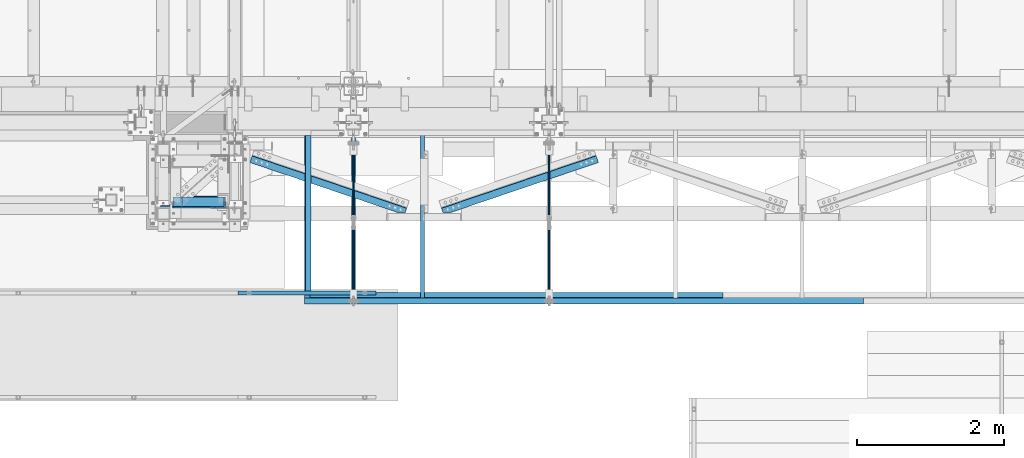
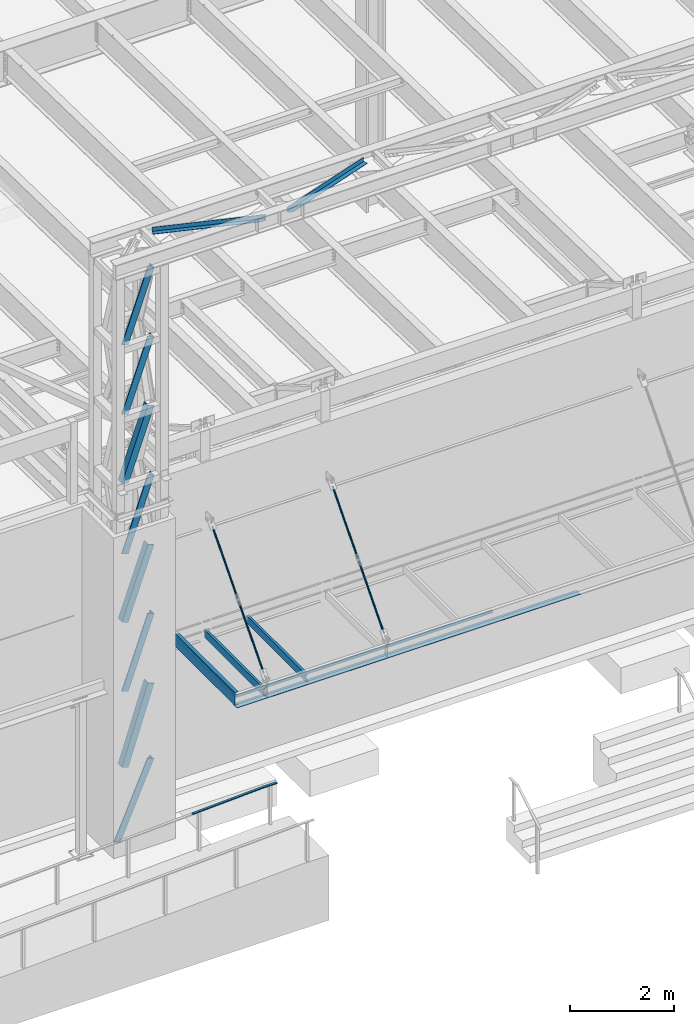
# One storey, part 1052 of 1763: 12 members, 9 beams, 10 elements without a shape of their own.
"""IFC2X3 building model written with IfcOpenShell, lengths in millimetres."""

import ifcopenshell
import ifcopenshell.guid

model = None  # the IFC model being written
_history = None  # IfcOwnerHistory: only IFC2X3 demands one
_inside = {}  # id of a spatial element -> (the spatial element, [elements in it])
_under = {}  # id of a project, library or spatial element -> (it, [spatial elements below it])
_declared = {}  # id of a project -> (the project, [libraries it declares])
_typed = {}  # id of a type object -> (the type object, [elements of that type])
_made_of = {}  # id of a material, layer set ... -> (it, [elements and type objects made of it])


def new_model(schema):
    """Start an empty IFC model of exactly this schema.

    Asked for "IFC4X3", IfcOpenShell would pick the latest addendum, in which some entities
    have other attributes; the version numbers below select the first issue.
    IFC2X3 requires an IfcOwnerHistory on every rooted entity: one is made here for all.
    """
    global model, _history
    if schema == "IFC4X3":
        model = ifcopenshell.file(schema_version=(4, 3, 0, 0))
    else:
        model = ifcopenshell.file(schema=schema)
    _inside.clear()
    _under.clear()
    _declared.clear()
    _typed.clear()
    _made_of.clear()
    _history = None
    if model.schema == "IFC2X3":
        org = make("IfcOrganization", Name="unknown")
        user = make(
            "IfcPersonAndOrganization",
            ThePerson=make("IfcPerson", FamilyName="unknown"),
            TheOrganization=org,
        )
        app = make(
            "IfcApplication",
            ApplicationDeveloper=org,
            Version="unknown",
            ApplicationFullName="unknown",
            ApplicationIdentifier="unknown",
        )
        _history = make(
            "IfcOwnerHistory",
            OwningUser=user,
            OwningApplication=app,
            ChangeAction="ADDED",
            CreationDate=0,
        )
    return model


def make(cls, **values):
    """One entity of the class cls with the attributes given. An attribute that is None is left unset."""
    return model.create_entity(
        cls, **{name: value for name, value in values.items() if value is not None}
    )


def rooted(cls, **values):
    """An entity with a GlobalId (a new one), such as an element, a storey or a relation."""
    return make(cls, GlobalId=ifcopenshell.guid.new(), OwnerHistory=_history, **values)


def si_unit(unit_type, name, prefix=None):
    """IfcSIUnit, for example si_unit("LENGTHUNIT", "METRE", prefix="MILLI")."""
    return make("IfcSIUnit", UnitType=unit_type, Prefix=prefix, Name=name)


def assignment(units):
    """IfcUnitAssignment: the units of a project."""
    return None if units is None else make("IfcUnitAssignment", Units=units)


def point(xyz):
    """IfcCartesianPoint."""
    return None if xyz is None else make("IfcCartesianPoint", Coordinates=xyz)


def direction(xyz):
    """IfcDirection."""
    return None if xyz is None else make("IfcDirection", DirectionRatios=xyz)


def frame(location, z_axis=None, x_axis=None):
    """IfcAxis2Placement3D, a coordinate frame: its origin and axes. An axis left out is left unset."""
    return make(
        "IfcAxis2Placement3D",
        Location=point(location),
        Axis=direction(z_axis),
        RefDirection=direction(x_axis),
    )


def origin_with_axes():
    """The frame at (0, 0, 0) with the z axis (0, 0, 1) and the x axis (1, 0, 0) written out."""
    return frame((0.0, 0.0, 0.0), z_axis=(0.0, 0.0, 1.0), x_axis=(1.0, 0.0, 0.0))


def place(relative_to, where):
    """IfcLocalPlacement: puts the frame where relative to a parent placement (None: the world)."""
    return make(
        "IfcLocalPlacement", PlacementRelTo=relative_to, RelativePlacement=where
    )


def context(
    kind, dimensions, precision=None, world=None, true_north=None, identifier=None
):
    """IfcGeometricRepresentationContext, for example the 3D "Model" context."""
    return make(
        "IfcGeometricRepresentationContext",
        ContextIdentifier=identifier,
        ContextType=kind,
        CoordinateSpaceDimension=dimensions,
        Precision=precision,
        WorldCoordinateSystem=world,
        TrueNorth=true_north,
    )


def subcontext(parent, identifier, kind, view, scale=None):
    """IfcGeometricRepresentationSubContext, for example "Body" below "Model"."""
    return make(
        "IfcGeometricRepresentationSubContext",
        ContextIdentifier=identifier,
        ContextType=kind,
        ParentContext=parent,
        TargetScale=scale,
        TargetView=view,
    )


def project(units=None, contexts=None):
    """IfcProject with its units and contexts."""
    return rooted(
        "IfcProject",
        Name="project",
        RepresentationContexts=contexts,
        UnitsInContext=assignment(units),
    )


def spatial(cls, under=None, at=None, **own):
    """A site, building, storey or space (cls), placed at a placement, below another one or the project."""
    s = rooted(cls, ObjectPlacement=at, **own)
    if under is not None:
        _under.setdefault(under.id(), (under, []))[1].append(s)
    return s


def faces_of(points, faces, orient=None, outer=None):
    """IfcFace entities. A face is a list of loops; a loop is a list of indices into points, from 0.

    orient and outer hold one flag for each loop. By default every Orientation is true, the
    first loop of a face is its IfcFaceOuterBound and the others are IfcFaceBound.
    """
    made = []
    for i, loops in enumerate(faces):
        bounds = []
        for j, loop in enumerate(loops):
            is_outer = j == 0 if outer is None else outer[i][j]
            bounds.append(
                make(
                    "IfcFaceOuterBound" if is_outer else "IfcFaceBound",
                    Bound=make("IfcPolyLoop", Polygon=[points[k] for k in loop]),
                    Orientation=True if orient is None else orient[i][j],
                )
            )
        made.append(make("IfcFace", Bounds=bounds))
    return made


def faceted_brep(points, faces, orient=None, outer=None, voids=None):
    """IfcFacetedBrep: a solid bounded by flat faces; with voids (closed shells), ...WithVoids."""
    shared = [point(p) for p in points]
    hull = make("IfcClosedShell", CfsFaces=faces_of(shared, faces, orient, outer))
    if voids is None:
        return make("IfcFacetedBrep", Outer=hull)
    return make(
        "IfcFacetedBrepWithVoids",
        Outer=hull,
        Voids=[
            make(cls, CfsFaces=faces_of(shared, fs, o, b)) for cls, fs, o, b in voids
        ],
    )


def shape(context_of_items, identifier, shape_type, items):
    """IfcShapeRepresentation: the items that make up one representation, for example the "Body"."""
    return make(
        "IfcShapeRepresentation",
        ContextOfItems=context_of_items,
        RepresentationIdentifier=identifier,
        RepresentationType=shape_type,
        Items=items,
    )


def material(Name=None, Category=None):
    """IfcMaterial."""
    return make("IfcMaterial", Name=Name, Category=Category)


def made_of(thing, what):
    """Note that an element or type object is made of a material, layer set ...; save() writes the relation."""
    if what is not None:
        _made_of.setdefault(what.id(), (what, []))[1].append(thing)
    return thing


def type_object(cls, material=None, **own):
    """A type object (cls), such as IfcWallType, which elements share."""
    return made_of(rooted(cls, **own), material)


def element(
    cls,
    number,
    at=None,
    inside=None,
    cuts=None,
    type_object=None,
    material=None,
    context=None,
    identifier="Body",
    shape_type=None,
    held_by="IfcProductDefinitionShape",
    body=None,
    shapes=None,
    **own,
):
    """One element of the class cls, such as IfcWall. Its Tag is "e" and its number.

    at: its placement. inside: the storey or other place that contains it. cuts: it is an
    opening in that element (IfcRelVoidsElement). A single representation is given by context,
    identifier, shape_type and body (its items); several are given by shapes. held_by: the class
    of the entity that holds the representations. save() writes the other relations.
    """
    e = rooted(cls, Tag="e%d" % number, ObjectPlacement=at, **own)
    if body is not None:
        shapes = [shape(context, identifier, shape_type, body)]
    if shapes is not None:
        e.Representation = make(held_by, Representations=shapes)
    if inside is not None:
        _inside.setdefault(inside.id(), (inside, []))[1].append(e)
    if cuts is not None:
        rooted(
            "IfcRelVoidsElement", RelatingBuildingElement=cuts, RelatedOpeningElement=e
        )
    if type_object is not None:
        _typed.setdefault(type_object.id(), (type_object, []))[1].append(e)
    return made_of(e, material)


def aggregate(whole, parts):
    """IfcRelAggregates: a whole, such as a stair, and the parts it consists of."""
    return rooted("IfcRelAggregates", RelatingObject=whole, RelatedObjects=parts)


def save(model, path):
    """Write the relations noted so far, then the file.

    IfcRelAggregates (storeys below a building ...), IfcRelContainedInSpatialStructure (elements
    in a storey), IfcRelDefinesByType, IfcRelAssociatesMaterial and IfcRelDeclares: one each for
    every whole, place, type object, material and project.
    """
    for whole, parts in _under.values():
        aggregate(whole, parts)
    for where, things in _inside.values():
        rooted(
            "IfcRelContainedInSpatialStructure",
            RelatedElements=things,
            RelatingStructure=where,
        )
    for kind, things in _typed.values():
        rooted("IfcRelDefinesByType", RelatedObjects=things, RelatingType=kind)
    for what, things in _made_of.values():
        rooted("IfcRelAssociatesMaterial", RelatedObjects=things, RelatingMaterial=what)
    for by, libraries in _declared.values():
        rooted("IfcRelDeclares", RelatingContext=by, RelatedDefinitions=libraries)
    model.write(path)


model = new_model("IFC2X3")

# Units and contexts
model_context = context("Model", 3, precision=1e-05, world=origin_with_axes())
body_context = subcontext(model_context, "Body", "Model", "MODEL_VIEW")
ifc_project = project(units=[si_unit("LENGTHUNIT", "METRE", prefix="MILLI"), si_unit("AREAUNIT", "SQUARE_METRE"), si_unit("VOLUMEUNIT", "CUBIC_METRE"), si_unit("MASSUNIT", "GRAM", prefix="KILO"), si_unit("TIMEUNIT", "SECOND"), si_unit("PLANEANGLEUNIT", "RADIAN"), si_unit("SOLIDANGLEUNIT", "STERADIAN"), si_unit("THERMODYNAMICTEMPERATUREUNIT", "DEGREE_CELSIUS"), si_unit("LUMINOUSINTENSITYUNIT", "LUMEN")], contexts=[model_context])

# Site, building, storey
site_placement = place(None, origin_with_axes())
site = spatial("IfcSite", under=ifc_project, at=site_placement, CompositionType="ELEMENT")
building_placement = place(site_placement, origin_with_axes())
building = spatial("IfcBuilding", under=site, at=building_placement, Name="Undefined", CompositionType="ELEMENT")
storey_placement = place(building_placement, origin_with_axes())
storey = spatial("IfcBuildingStorey", under=building, at=storey_placement, Name="Undefined", CompositionType="ELEMENT", Elevation=0.0)

# Assembly, members
assembly_1_placement = place(storey_placement, origin_with_axes())
assembly_1 = element("IfcElementAssembly", 1, at=assembly_1_placement, inside=storey, Name="FRAME", AssemblyPlace="NOTDEFINED", PredefinedType="RIGID_FRAME")
ifc_material_1 = material(Name="STEEL/A36")
member_type_1 = type_object("IfcMemberType", Name="L6X6X7/8", PredefinedType="NOTDEFINED")
member_1_placement = place(assembly_1_placement, frame((-63987.0213595113, -15300.3290302764, 16748.720313), z_axis=(-5.63699999961987e-06, 0.999999999984112, 0.0), x_axis=(0.335283282133074, 2.03400000119903e-06, 0.942117360373927)))
member_1 = element("IfcMember", 2, at=member_1_placement, type_object=member_type_1, material=ifc_material_1, Name="V. BRACE", ObjectType="L6X6X7/8", context=body_context, shape_type="Brep", body=[
    faceted_brep([(9.09494701772928e-13, 76.2000000000007, -76.2000000000844), (0.0, 76.2000000000007, 76.2000000000771), (1724.84329343789, 76.1999999996478, 76.2000000010958), (1724.84329343754, 76.2000000000044, -76.1999999989348), (0.0, 53.9750000000004, 76.2000000000771), (1724.84329343786, 53.9749999996711, 76.2000000010812), (1.81898940354586e-12, 53.9750000000004, -53.9750000000604), (1724.84329343756, 53.9749999999767, -53.9749999989453), (1.81898940354586e-12, -76.2000000000007, -53.9750000000604), (1724.84329343738, -76.1999999998734, -53.9749999990436), (9.09494701772928e-13, -76.2000000000007, -76.2000000000844), (1724.84329343733, -76.1999999998225, -76.1999999990512)], [[[0, 1, 2, 3]], [[1, 4, 5, 2]], [[4, 6, 7, 5]], [[6, 8, 9, 7]], [[8, 10, 11, 9]], [[10, 0, 3, 11]], [[5, 7, 9, 11, 3, 2]], [[10, 8, 6, 4, 1, 0]]]),
])
member_2_placement = place(assembly_1_placement, frame((-63986.7900957031, -15300.3290302764, 15123.7156239956), z_axis=(0.0, 1.0, 0.0), x_axis=(0.334874224906127, 9.99999833869425e-10, 0.942262836735866)))
member_2 = element("IfcMember", 3, at=member_2_placement, type_object=member_type_1, material=ifc_material_1, Name="V. BRACE", ObjectType="L6X6X7/8", context=body_context, shape_type="Brep", body=[
    faceted_brep([(9.09494701772928e-13, 76.2000000000007, -76.2000000000844), (0.0, 76.2000000000007, 76.2000000000771), (1724.57686399414, 76.1999999983163, 76.1999999992258), (1724.57686399422, 76.1999999981927, -76.2000000007738), (0.0, 53.9750000000004, 76.2000000000771), (1724.57686399418, 53.974999998245, 76.1999999992295), (1.81898940354586e-12, 53.9750000000004, -53.9750000000604), (1724.57686399425, 53.9749999981432, -53.9750000007716), (1.81898940354586e-12, -76.2000000000007, -53.9750000000604), (1724.57686399449, -76.2000000022381, -53.9750000007571), (9.09494701772928e-13, -76.2000000000007, -76.2000000000844), (1724.5768639945, -76.2000000022599, -76.2000000007574)], [[[0, 1, 2, 3]], [[1, 4, 5, 2]], [[4, 6, 7, 5]], [[6, 8, 9, 7]], [[8, 10, 11, 9]], [[10, 0, 3, 11]], [[5, 7, 9, 11, 3, 2]], [[10, 8, 6, 4, 1, 0]]]),
])
member_3_placement = place(assembly_1_placement, frame((-63987.4603919911, -15300.3290302764, 13498.7109359956), z_axis=(0.941969969892365, 3.99999953515362e-09, -0.335697148961644), x_axis=(0.335697148961641, 9.99999941453763e-10, 0.941969969892367)))
member_3 = element("IfcMember", 4, at=member_3_placement, type_object=member_type_1, material=ifc_material_1, Name="V. BRACE", ObjectType="L6X6X7/8", context=body_context, shape_type="Brep", body=[
    faceted_brep([(9.09494701772928e-13, 76.2000000000007, -76.2000000000844), (0.0, 76.2000000000007, 76.2000000000771), (1725.11328041713, 76.1999999975596, 76.1999999991767), (1725.11328041723, 76.1999999976688, -76.2000000008229), (0.0, 53.9750000000004, 76.2000000000771), (1725.11328041714, 53.9749999975757, 76.1999999991931), (1.81898940354586e-12, 53.9750000000004, -53.9750000000604), (1725.11328041723, 53.9749999976702, -53.975000000808), (1.81898940354586e-12, -76.2000000000007, -53.9750000000604), (1725.11328041727, -76.2000000022526, -53.9750000007098), (9.09494701772928e-13, -76.2000000000007, -76.2000000000844), (1725.11328041728, -76.2000000022454, -76.2000000007101)], [[[0, 1, 2, 3]], [[1, 4, 5, 2]], [[4, 6, 7, 5]], [[6, 8, 9, 7]], [[8, 10, 11, 9]], [[10, 0, 3, 11]], [[5, 7, 9, 11, 3, 2]], [[10, 8, 6, 4, 1, 0]]]),
])
member_4_placement = place(assembly_1_placement, frame((-63986.5973864284, -15300.3290302764, 11849.0999999956), z_axis=(0.0, 1.0, 0.0), x_axis=(0.330549340153199, 9.99999554506466e-10, 0.943788712437421)))
member_4 = element("IfcMember", 5, at=member_4_placement, type_object=member_type_1, material=ifc_material_1, Name="V. BRACE", ObjectType="L6X6X7/8", context=body_context, shape_type="Brep", body=[
    faceted_brep([(9.09494701772928e-13, 76.2000000000007, -76.2000000000844), (0.0, 76.2000000000007, 76.2000000000771), (1747.86042051722, 76.1999999938562, 76.199999999164), (1747.86042051722, 76.1999999937107, -76.2000000008356), (0.0, 53.9750000000004, 76.2000000000771), (1747.86042051722, 53.9749999938722, 76.1999999991804), (1.81898940354586e-12, 53.9750000000004, -53.9750000000604), (1747.86042051722, 53.9749999937558, -53.9750000008189), (1.81898940354586e-12, -76.2000000000007, -53.9750000000604), (1747.86042051721, -76.2000000061671, -53.9750000007189), (9.09494701772928e-13, -76.2000000000007, -76.2000000000844), (1747.86042051721, -76.2000000061889, -76.2000000007192)], [[[0, 1, 2, 3]], [[1, 4, 5, 2]], [[4, 6, 7, 5]], [[6, 8, 9, 7]], [[8, 10, 11, 9]], [[10, 0, 3, 11]], [[5, 7, 9, 11, 3, 2]], [[10, 8, 6, 4, 1, 0]]]),
])
member_5_placement = place(assembly_1_placement, frame((-63986.1285602919, -15300.3290302764, 10248.701776542), z_axis=(0.942338290337835, 3.99999953515361e-09, -0.334661839119978), x_axis=(0.33466183911998, 9.99999794265608e-10, 0.942338290337834)))
member_5 = element("IfcMember", 6, at=member_5_placement, type_object=member_type_1, material=ifc_material_1, Name="V. BRACE", ObjectType="L6X6X7/8", context=body_context, shape_type="Brep", body=[
    faceted_brep([(9.09494701772928e-13, 76.2000000000007, -76.2000000000844), (0.0, 76.2000000000007, 76.2000000000771), (1724.4605169534, 76.1999999968903, 76.199999999204), (1724.46051695335, 76.1999999966574, -76.2000000007956), (0.0, 53.9750000000004, 76.2000000000771), (1724.46051695341, 53.9749999968262, 76.1999999992131), (1.81898940354586e-12, 53.9750000000004, -53.9750000000604), (1724.46051695337, 53.9749999966371, -53.975000000788), (1.81898940354586e-12, -76.2000000000007, -53.9750000000604), (1724.46051695341, -76.2000000037297, -53.9750000007334), (9.09494701772928e-13, -76.2000000000007, -76.2000000000844), (1724.4605169534, -76.2000000037588, -76.2000000007338)], [[[0, 1, 2, 3]], [[1, 4, 5, 2]], [[4, 6, 7, 5]], [[6, 8, 9, 7]], [[8, 10, 11, 9]], [[10, 0, 3, 11]], [[5, 7, 9, 11, 3, 2]], [[10, 8, 6, 4, 1, 0]]]),
])
member_6_placement = place(assembly_1_placement, frame((-63986.7095248402, -15300.3290302764, 8623.3), z_axis=(0.0, 1.0, 0.0), x_axis=(0.334512951060313, 1.00000043783993e-09, 0.942391153169914)))
member_6 = element("IfcMember", 7, at=member_6_placement, type_object=member_type_1, material=ifc_material_1, Name="V. BRACE", ObjectType="L6X6X7/8", context=body_context, shape_type="Brep", body=[
    faceted_brep([(9.09494701772928e-13, 76.2000000000007, -76.2000000000844), (0.0, 76.2000000000007, 76.2000000000771), (1724.76317823229, 76.1999999951586, 76.1999999991876), (1724.76317823233, 76.199999994933, -76.200000000812), (0.0, 53.9750000000004, 76.2000000000771), (1724.7631782323, 53.97499999516, 76.1999999992004), (1.81898940354586e-12, 53.9750000000004, -53.9750000000604), (1724.76317823234, 53.9749999949636, -53.9750000007989), (1.81898940354586e-12, -76.2000000000007, -53.9750000000604), (1724.76317823241, -76.2000000050757, -53.975000000717), (9.09494701772928e-13, -76.2000000000007, -76.2000000000844), (1724.76317823241, -76.2000000050975, -76.2000000007174)], [[[0, 1, 2, 3]], [[1, 4, 5, 2]], [[4, 6, 7, 5]], [[6, 8, 9, 7]], [[8, 10, 11, 9]], [[10, 0, 3, 11]], [[5, 7, 9, 11, 3, 2]], [[10, 8, 6, 4, 1, 0]]]),
])
member_7_placement = place(assembly_1_placement, frame((-63985.9949216758, -15300.3290302764, 6845.30021654201), z_axis=(0.951343767819845, 3.99999953515362e-09, -0.30813152294165), x_axis=(0.308131522941648, 1.00000004810686e-09, 0.951343767819846)))
member_7 = element("IfcMember", 8, at=member_7_placement, type_object=member_type_1, material=ifc_material_1, Name="V. BRACE", ObjectType="L6X6X7/8", context=body_context, shape_type="Brep", body=[
    faceted_brep([(9.09494701772928e-13, 76.2000000000007, -76.2000000000844), (0.0, 76.2000000000007, 76.2000000000771), (1868.93512461962, 76.199999997596, 76.1999999991676), (1868.93512461956, 76.1999999976761, -76.2000000008338), (0.0, 53.9750000000004, 76.2000000000771), (1868.9351246196, 53.9749999976411, 76.1999999991676), (1.81898940354586e-12, 53.9750000000004, -53.9750000000604), (1868.93512461955, 53.9749999977066, -53.9750000008316), (1.81898940354586e-12, -76.2000000000007, -53.9750000000604), (1868.93512461943, -76.2000000020707, -53.975000000828), (9.09494701772928e-13, -76.2000000000007, -76.2000000000844), (1868.93512461942, -76.2000000020489, -76.2000000008265)], [[[0, 1, 2, 3]], [[1, 4, 5, 2]], [[4, 6, 7, 5]], [[6, 8, 9, 7]], [[8, 10, 11, 9]], [[10, 0, 3, 11]], [[5, 7, 9, 11, 3, 2]], [[10, 8, 6, 4, 1, 0]]]),
])
member_8_placement = place(assembly_1_placement, frame((-64185.2277918511, -15287.629029286, 5067.3), z_axis=(0.0, 1.0, 0.0), x_axis=(0.400955294202786, 1.00000025355767e-09, 0.916097621463323)))
member_8 = element("IfcMember", 9, at=member_8_placement, type_object=member_type_1, material=ifc_material_1, Name="V. BRACE", ObjectType="L6X6X7/8", context=body_context, shape_type="Brep", body=[
    faceted_brep([(74.9404777348027, 76.199999999888, -76.2000000000044), (74.9404778871212, 76.1999999996915, 76.1999999999953), (1940.84119258349, 76.2000000036787, 76.1999999991021), (1940.84119258334, 76.2000000038752, -76.2000000008975), (74.9404778871649, 53.9749999997148, 76.200000000008), (1940.84119258348, 53.9750000036947, 76.1999999991149), (74.9404777570599, 53.9749999998676, -53.9749999999931), (1940.84119258335, 53.9750000038621, -53.9750000008862), (74.9404777573181, -76.2000000000189, -53.9749999999312), (1940.84119258335, -76.199999996039, -53.9750000008244), (74.9404777351083, -76.1999999999971, -76.1999999999316), (1940.84119258333, -76.1999999960099, -76.2000000008247)], [[[0, 1, 2, 3]], [[1, 4, 5, 2]], [[4, 6, 7, 5]], [[6, 8, 9, 7]], [[8, 10, 11, 9]], [[10, 0, 3, 11]], [[5, 7, 9, 11, 3, 2]], [[10, 8, 6, 4, 1, 0]]]),
])
aggregate(assembly_1, [member_1, member_2, member_3, member_4, member_5, member_6, member_7, member_8])

# Assembly, beam
assembly_2_placement = place(storey_placement, origin_with_axes())
assembly_2 = element("IfcElementAssembly", 10, at=assembly_2_placement, inside=storey, Name="BEAM", AssemblyPlace="NOTDEFINED", PredefinedType="RIGID_FRAME")
beam_type_1 = type_object("IfcBeamType", Name="C12X20.7", PredefinedType="NOTDEFINED")
beam_1_placement = place(assembly_2_placement, frame((-62222.878570321, -16605.2525869816, 8585.2), z_axis=(0.0, 0.0, 1.0), x_axis=(0.0, 1.0, 0.0)))
beam_1 = element("IfcBeam", 11, at=beam_1_placement, type_object=beam_type_1, material=ifc_material_1, Name="BEAM", ObjectType="C12X20.7", context=body_context, shape_type="Brep", body=[
    faceted_brep([(0.0, 38.1000000000004, -152.4), (0.0, 38.1000000000004, 152.4), (2295.52500000448, 38.0999999999985, 152.4), (2295.52500000448, 38.0999999999985, -152.4), (0.0, -38.1000000000004, 152.4), (2295.52500000448, -38.0999999999985, 152.4), (0.0, -38.1000000000004, 146.04746), (2295.52500000448, -38.0999999999985, 146.04746), (0.0, 30.1625000000004, 134.6749275), (2295.52500000448, 30.1624999999985, 134.6749275), (0.0, 30.1625000000004, -134.6749275), (2295.52500000448, 30.1624999999985, -134.6749275), (0.0, -38.1000000000004, -146.04746), (2295.52500000448, -38.0999999999985, -146.04746), (0.0, -38.1000000000004, -152.4), (2295.52500000448, -38.0999999999985, -152.4)], [[[0, 1, 2, 3]], [[1, 4, 5, 2]], [[4, 6, 7, 5]], [[6, 8, 9, 7]], [[8, 10, 11, 9]], [[10, 12, 13, 11]], [[12, 14, 15, 13]], [[14, 0, 3, 15]], [[5, 7, 9, 11, 13, 15, 3, 2]], [[14, 12, 10, 8, 6, 4, 1, 0]]]),
])

assembly_3_placement = place(storey_placement, origin_with_axes())
assembly_3 = element("IfcElementAssembly", 12, at=assembly_3_placement, inside=storey, Name="ANGLE", AssemblyPlace="NOTDEFINED", PredefinedType="RIGID_FRAME")
beam_type_2 = type_object("IfcBeamType", Name="L4X4X1/4", PredefinedType="NOTDEFINED")
beam_2_placement = place(assembly_3_placement, frame((-60647.6330235447, -15500.8450363274, 18672.175), z_axis=(-0.320645554004404, -0.947199255013014, 0.0), x_axis=(-0.947199255013015, 0.320645554004401, 0.0)))
beam_2 = element("IfcBeam", 13, at=beam_2_placement, type_object=beam_type_2, material=ifc_material_1, Name="ANGLE", ObjectType="L4X4X1/4", context=body_context, shape_type="Brep", body=[
    faceted_brep([(248.935656765898, 44.4500000000007, 15.0335884778251), (248.935656765898, 50.7999999999993, 15.0335884778251), (248.93475632761, 50.7999999999993, -50.7999999996973), (248.93475632761, -50.7999999999993, -50.7999999996973), (248.934843627998, -50.7999999999993, -44.4500000001863), (248.934843627998, 44.4500000000007, -44.4500000001863), (354.576694317358, 44.4500000000007, 50.7951525150202), (354.576694317358, 50.7999999999993, 50.7999999998283), (2474.101738043, 44.4500000000007, 50.7994905337837), (2474.101738043, 50.7999999999993, 50.7999999985695), (2474.10174137646, 50.7999999999993, -50.7999999971726), (2474.10174137646, -50.7999999999993, -50.7999999971726), (2474.1017380429, -50.7999999999993, -44.4500000015032), (2474.1017380429, 44.4500000000007, -44.4500000015032)], [[[0, 1, 2, 3, 4, 5]], [[6, 7, 1, 0]], [[7, 6, 8, 9]], [[2, 1, 7, 9, 10]], [[3, 2, 10, 11]], [[4, 3, 11, 12]], [[5, 4, 12, 13]], [[6, 0, 5, 13, 8]], [[12, 11, 10, 9, 8, 13]]]),
])
aggregate(assembly_3, [beam_2])

assembly_4_placement = place(storey_placement, origin_with_axes())
assembly_4 = element("IfcElementAssembly", 14, at=assembly_4_placement, inside=storey, Name="ANGLE", AssemblyPlace="NOTDEFINED", PredefinedType="RIGID_FRAME")
beam_3_placement = place(assembly_4_placement, frame((-58035.897064475, -14627.719968568, 18672.175), z_axis=(0.320645554004404, -0.947199255013014, 0.0), x_axis=(-0.947199255013014, -0.320645554004406, 0.0)))
beam_3 = element("IfcBeam", 15, at=beam_3_placement, type_object=beam_type_2, material=ifc_material_1, Name="ANGLE", ObjectType="L4X4X1/4", context=body_context, shape_type="Brep", body=[
    faceted_brep([(2474.08768654509, 44.4500000000007, -44.4499999985737), (2474.08768654509, -50.7999999999993, -44.4499999985737), (2474.08778122983, -50.7999999999993, -50.7999999984352), (2474.08778122983, 50.7999999999993, -50.7999999984352), (2474.08687340719, 50.7999999999993, 15.0335884763126), (2474.08687340719, 44.4500000000007, 15.0335884763126), (2368.44583585572, 50.7999999999993, 50.8000000014445), (2368.44583585572, 44.4500000000007, 50.8000000014445), (248.920792117679, 44.4500000000007, 50.8000000001839), (248.92079211778, 44.4500000000007, -44.4499999998907), (248.92079211778, -50.7999999999993, -44.4499999998907), (248.920795180988, -50.7999999999993, -50.7999999998303), (248.920795180988, 50.7999999999993, -50.7999999998303), (248.920792117679, 50.7999999999993, 50.8000000001839)], [[[0, 1, 2, 3, 4, 5]], [[5, 4, 6, 7]], [[0, 5, 7, 8, 9]], [[1, 0, 9, 10]], [[2, 1, 10, 11]], [[3, 2, 11, 12]], [[6, 4, 3, 12, 13]], [[7, 6, 13, 8]], [[12, 11, 10, 9, 8, 13]]]),
])
aggregate(assembly_4, [beam_3])

# Beam
beam_type_3 = type_object("IfcBeamType", Name="L3X3X1/4", PredefinedType="NOTDEFINED")
beam_4_placement = place(assembly_2_placement, frame((-62214.9410885321, -14389.1026138803, 8648.7), z_axis=(1.0, 0.0, 0.0), x_axis=(0.0, -1.0, 0.0)))
beam_4 = element("IfcBeam", 16, at=beam_4_placement, type_object=beam_type_3, material=ifc_material_1, Name="ANGLE", ObjectType="L3X3X1/4", context=body_context, shape_type="Brep", body=[
    faceted_brep([(0.0, 38.0999999999985, -38.1000000000004), (0.0, 38.0999999999985, 38.1000000000004), (2127.24997269495, 38.1000000000004, 38.1000000007625), (2127.24997269498, 38.1000000000004, -38.0999999992346), (0.0, 31.75, 38.1000000000058), (2127.24997269495, 31.75, 38.1000000007625), (0.0, 31.75, -31.75), (2127.24997269498, 31.75, -31.749999999236), (0.0, -38.1000000000004, -31.75), (2127.24997269498, -38.1000000000004, -31.749999999236), (0.0, -38.0999999999985, -38.1000000000004), (2127.24997269498, -38.1000000000004, -38.0999999992346)], [[[0, 1, 2, 3]], [[1, 4, 5, 2]], [[4, 6, 7, 5]], [[6, 8, 9, 7]], [[8, 10, 11, 9]], [[10, 0, 3, 11]], [[5, 7, 9, 11, 3, 2]], [[10, 8, 6, 4, 1, 0]]]),
])

aggregate(assembly_2, [beam_4, beam_1])

# Assembly, beam
assembly_5_placement = place(storey_placement, origin_with_axes())
assembly_5 = element("IfcElementAssembly", 17, at=assembly_5_placement, inside=storey, Name="BEAM", AssemblyPlace="NOTDEFINED", PredefinedType="RIGID_FRAME")
beam_5_placement = place(assembly_5_placement, frame((-62240.3410736523, -16567.1525870962, 8648.7), z_axis=(0.0, 1.0, 0.0), x_axis=(1.0, 0.0, 0.0)))
beam_5 = element("IfcBeam", 18, at=beam_5_placement, type_object=beam_type_3, material=ifc_material_1, Name="ANGLE", ObjectType="L3X3X1/4", context=body_context, shape_type="Brep", body=[
    faceted_brep([(0.0, 38.0999999999985, -38.1000000000004), (0.0, 38.0999999999985, 38.1000000000004), (5686.02812397742, 38.1000000000004, 38.0999999921842), (5686.02812397732, 38.1000000000004, -38.1000000078166), (0.0, 31.75, 38.1000000000058), (5686.02812397742, 31.75, 38.0999999921842), (0.0, 31.75, -31.75), (5686.02812397732, 31.75, -31.7500000078144), (0.0, -38.1000000000004, -31.75), (5686.02812397732, -38.1000000000004, -31.7500000078144), (0.0, -38.0999999999985, -38.1000000000004), (5686.02812397732, -38.1000000000004, -38.1000000078166)], [[[0, 1, 2, 3]], [[1, 4, 5, 2]], [[4, 6, 7, 5]], [[6, 8, 9, 7]], [[8, 10, 11, 9]], [[10, 0, 3, 11]], [[5, 7, 9, 11, 3, 2]], [[10, 8, 6, 4, 1, 0]]]),
])

assembly_6_placement = place(storey_placement, origin_with_axes())
assembly_6 = element("IfcElementAssembly", 19, at=assembly_6_placement, inside=storey, Name="HANDRAIL", AssemblyPlace="NOTDEFINED", PredefinedType="RIGID_FRAME")
beam_type_4 = type_object("IfcBeamType", PredefinedType="NOTDEFINED")
beam_6_placement = place(assembly_6_placement, frame((-63170.3544175437, -16535.40011631, 6173.15296081485), z_axis=(0.0, 1.0, 0.0), x_axis=(0.998862153652615, 0.0, 0.0476906489834141)))
beam_6 = element("IfcBeam", 20, at=beam_6_placement, type_object=beam_type_4, material=ifc_material_1, Name="HANDRAIL", context=body_context, shape_type="Brep", body=[
    faceted_brep([(2.91038304567337e-11, -9.52499999999418, -25.4000000000015), (2.91038304567337e-11, -9.52499999999418, 25.4000000000015), (-5.82076609134674e-11, 9.52499999999418, 25.4000000000015), (-5.82076609134674e-11, 9.52499999999418, -25.4000000000015), (1577.64893967877, 9.5250031540254, 25.4000000000015), (1577.64893967877, 9.5250031540254, -25.4000000000015), (1578.10337826535, -9.52499684506802, -25.4000000000015), (1578.10337826535, -9.52499684506802, 25.4000000000015), (1881.72603368139, 24.0408078176079, 25.4000000000015), (1881.72603368139, 24.0408078176079, -25.4000000000015), (1882.63439390225, 5.01247678966138, 25.4000000000015), (1882.63439390225, 5.01247678966138, -25.4000000000015)], [[[0, 1, 2, 3]], [[3, 2, 4, 5]], [[1, 0, 6, 7]], [[5, 4, 8, 9]], [[4, 2, 1, 7, 10, 8]], [[7, 6, 11, 10]], [[6, 0, 3, 5, 9, 11]], [[10, 11, 9, 8]]]),
])
aggregate(assembly_6, [beam_6])

# Beam
beam_type_5 = type_object("IfcBeamType", PredefinedType="NOTDEFINED")
beam_7_placement = place(assembly_5_placement, frame((-62260.9785706929, -16605.2525869363, 8426.45), z_axis=(0.0, 1.0, 0.0), x_axis=(1.0, 0.0, 0.0)))
beam_7 = element("IfcBeam", 21, at=beam_7_placement, type_object=beam_type_5, material=ifc_material_1, Name="PLATE", context=body_context, shape_type="Brep", body=[
    faceted_brep([(4.36557456851006e-11, 6.35000000000036, -76.2000000000044), (-4.72937244921923e-11, 6.35000000000036, 76.1999999999898), (7619.80156200011, 6.35000000000036, 76.1999999891996), (7619.80156199988, 6.35000000000036, -76.2000000107982), (-4.72937244921923e-11, -6.35000000000036, 76.1999999999898), (7619.80156200011, -6.35000000000036, 76.1999999891996), (4.36557456851006e-11, -6.35000000000036, -76.2000000000044), (7619.80156199988, -6.35000000000036, -76.2000000107982)], [[[0, 1, 2, 3]], [[1, 4, 5, 2]], [[4, 6, 7, 5]], [[6, 0, 3, 7]], [[5, 7, 3, 2]], [[6, 4, 1, 0]]]),
])

aggregate(assembly_5, [beam_5, beam_7])

# Assembly, beam
assembly_7_placement = place(storey_placement, origin_with_axes())
assembly_7 = element("IfcElementAssembly", 22, at=assembly_7_placement, inside=storey, Name="BEAM", AssemblyPlace="NOTDEFINED", PredefinedType="RIGID_FRAME")
beam_type_6 = type_object("IfcBeamType", Name="C7X9.8", PredefinedType="NOTDEFINED")
beam_8_placement = place(assembly_7_placement, frame((-61594.4270098568, -16605.2525869816, 8521.7), z_axis=(0.0, 0.0, 1.0), x_axis=(0.0, 1.0, 0.0)))
beam_8 = element("IfcBeam", 23, at=beam_8_placement, type_object=beam_type_6, material=ifc_material_1, Name="BEAM", ObjectType="C7X9.8", context=body_context, shape_type="Brep", body=[
    faceted_brep([(0.0, 26.9875000000029, -88.8999999999996), (0.0, 26.9875000000029, 88.8999999999996), (2295.52499752098, 26.9875000000029, 88.8999999999996), (2295.52499752098, 26.9875000000029, -88.8999999999996), (0.0, -26.9875000000029, 88.8999999999996), (2295.52499752098, -26.9875000000029, 88.8999999999996), (0.0, -26.9875000000029, 83.8711175000008), (2295.52499752098, -26.9875000000029, 83.8711175000008), (0.0, 22.2249999999985, 75.6723149999998), (2295.52499752098, 22.2249999999985, 75.6723149999998), (0.0, 22.2249999999985, -75.6723149999998), (2295.52499752098, 22.2249999999985, -75.6723149999998), (0.0, -26.9875000000029, -83.8711175000008), (2295.52499752098, -26.9875000000029, -83.8711175000008), (0.0, -26.9875000000029, -88.8999999999996), (2295.52499752098, -26.9875000000029, -88.8999999999996)], [[[0, 1, 2, 3]], [[1, 4, 5, 2]], [[4, 6, 7, 5]], [[6, 8, 9, 7]], [[8, 10, 11, 9]], [[10, 12, 13, 11]], [[12, 14, 15, 13]], [[14, 0, 3, 15]], [[5, 7, 9, 11, 13, 15, 3, 2]], [[14, 12, 10, 8, 6, 4, 1, 0]]]),
])
aggregate(assembly_7, [beam_8])

assembly_8_placement = place(storey_placement, origin_with_axes())
assembly_8 = element("IfcElementAssembly", 24, at=assembly_8_placement, inside=storey, Name="BEAM", AssemblyPlace="NOTDEFINED", PredefinedType="RIGID_FRAME")
beam_9_placement = place(assembly_8_placement, frame((-60655.4207602316, -16605.2525869012, 8521.7), z_axis=(0.0, 0.0, 1.0), x_axis=(0.0, 1.0, 0.0)))
beam_9 = element("IfcBeam", 25, at=beam_9_placement, type_object=beam_type_6, material=ifc_material_1, Name="BEAM", ObjectType="C7X9.8", context=body_context, shape_type="Brep", body=[
    faceted_brep([(0.0, 26.9875000000029, -88.8999999999996), (0.0, 26.9875000000029, 88.8999999999996), (2295.52499752098, 26.9875000000029, 88.8999999999996), (2295.52499752098, 26.9875000000029, -88.8999999999996), (0.0, -26.9875000000029, 88.8999999999996), (2295.52499752098, -26.9875000000029, 88.8999999999996), (0.0, -26.9875000000029, 83.8711175000008), (2295.52499752098, -26.9875000000029, 83.8711175000008), (0.0, 22.2249999999985, 75.6723149999998), (2295.52499752098, 22.2249999999985, 75.6723149999998), (0.0, 22.2249999999985, -75.6723149999998), (2295.52499752098, 22.2249999999985, -75.6723149999998), (0.0, -26.9875000000029, -83.8711175000008), (2295.52499752098, -26.9875000000029, -83.8711175000008), (0.0, -26.9875000000029, -88.8999999999996), (2295.52499752098, -26.9875000000029, -88.8999999999996)], [[[0, 1, 2, 3]], [[1, 4, 5, 2]], [[4, 6, 7, 5]], [[6, 8, 9, 7]], [[8, 10, 11, 9]], [[10, 12, 13, 11]], [[12, 14, 15, 13]], [[14, 0, 3, 15]], [[5, 7, 9, 11, 13, 15, 3, 2]], [[14, 12, 10, 8, 6, 4, 1, 0]]]),
])
aggregate(assembly_8, [beam_9])

# Assembly, members
assembly_9_placement = place(storey_placement, origin_with_axes())
assembly_9 = element("IfcElementAssembly", 26, at=assembly_9_placement, inside=storey, Name="HANGER ROD", AssemblyPlace="NOTDEFINED", PredefinedType="RIGID_FRAME")
ifc_material_2 = material()
member_type_2 = type_object("IfcMemberType", PredefinedType="NOTDEFINED")
member_9_placement = place(assembly_9_placement, frame((-58927.4270098567, -15572.8018593345, 10059.9757394587), z_axis=(0.0, -0.751852283110682, 0.659331589097061), x_axis=(0.0, 0.659331589097062, 0.75185228311068)))
member_9 = element("IfcMember", 27, at=member_9_placement, type_object=member_type_2, material=ifc_material_2, Name="BEAM", context=body_context, shape_type="Brep", body=[
    faceted_brep([(1503.04093508851, -7.9375, -13.7481532849306), (1503.04093478259, 0.0, -15.8749999998545), (1503.04093508851, 7.9375, -13.7481532849306), (1503.04093592429, 13.7481532850798, -7.93749999985448), (1503.04093706599, 15.875, 1.41881173476577e-10), (1503.0409382077, 13.7481532850798, 7.93750000013824), (1503.04093904348, 7.9375, 13.748153285218), (1503.0409393494, 0.0, 15.8750000001382), (1503.04093904348, -7.9375, 13.748153285218), (1503.0409382077, -13.7481532850798, 7.93750000013824), (1503.04093706599, -15.875, 1.41881173476577e-10), (1503.04093592429, -13.7481532850798, -7.93749999985448), (25.399999995976, -7.93750000389264, 13.7481538153661), (25.3999999959769, -3.89263732358813e-09, 15.8750005302863), (25.3999999959751, -13.7481532889724, 7.93750053028998), (25.3999999959788, -15.8750000038926, 5.30293618794531e-07), (25.3999999959779, -13.7481532889724, -7.93749946969911), (25.3999999959797, -7.93750000389264, -13.7481527547752), (25.3999999959797, -3.89263732358813e-09, -15.8749994696918), (25.3999999959797, 7.93749999610736, -13.7481527547752), (25.3999999959779, 13.7481532811871, -7.93749946969911), (25.3999996185303, 15.8749999962647, 0.0), (25.3999999959751, 13.7481532811871, 7.93750053028998), (25.399999995976, 7.93749999610736, 13.7481538153661), (177.799999998953, 7.9375, 13.7481532850943)], [[[0, 1, 2, 3, 4, 5, 6, 7, 8, 9, 10, 11]], [[12, 8, 7, 13]], [[14, 9, 8, 12]], [[15, 10, 9, 14]], [[16, 11, 10, 15]], [[17, 0, 11, 16]], [[18, 1, 0, 17]], [[19, 2, 1, 18]], [[20, 3, 2, 19]], [[21, 4, 3, 20]], [[22, 5, 4, 21]], [[23, 24, 6, 5, 22]], [[23, 13, 7, 6, 24]], [[22, 21, 20, 19, 18, 17, 16, 15, 14, 12, 13, 23]]]),
])
member_10_placement = place(assembly_9_placement, frame((-58927.4270098567, -16643.3525869814, 8839.20000000015), z_axis=(0.0, -0.751852283110682, 0.659331589097061), x_axis=(0.0, 0.659331589097062, 0.75185228311068)))
member_10 = element("IfcMember", 28, at=member_10_placement, type_object=member_type_2, material=ifc_material_2, Name="HANGER ROD", context=body_context, shape_type="Brep", body=[
    faceted_brep([(120.649999999407, -13.7481532850798, 7.93750000002183), (120.649999999399, -7.9375, 13.7481532851089), (120.649999999397, 0.0, 15.8750000000327), (120.649999999399, 7.9375, 13.7481532851089), (120.649999999407, 13.7481532850798, 7.93750000002183), (120.649999999417, 15.875, 1.45519152283669e-11), (120.649999999425, 13.7481532850798, -7.93749999999272), (120.649999999432, 7.9375, -13.7481532850798), (120.649999999433, 0.0, -15.875), (120.649999999432, -7.9375, -13.7481532850798), (120.649999999425, -13.7481532850798, -7.93749999999272), (120.649999999417, -15.875, 1.45519152283669e-11), (1598.29093934174, 7.9375, 13.7481532763995), (1598.29093934174, 0.0, 15.8749999913271), (1598.29093934175, 13.7481532850798, 7.93749999131251), (1598.29093934176, 15.875, -8.70568328537047e-09), (1598.29093934177, 13.7481532850798, -7.93750000872024), (1598.29093934178, 7.9375, -13.7481532938109), (1598.29093934178, 0.0, -15.8750000087384), (1598.29093934178, -7.9375, -13.7481532938109), (1598.29093934177, -13.7481532850798, -7.93750000872024), (1598.29093934176, -15.875, -8.70568328537047e-09), (1598.29093934175, -13.7481532850798, 7.93749999131251), (1598.29093934174, -7.9375, 13.7481532763995)], [[[0, 1, 2, 3, 4, 5, 6, 7, 8, 9, 10, 11]], [[12, 3, 2, 13]], [[14, 4, 3, 12]], [[15, 5, 4, 14]], [[16, 6, 5, 15]], [[17, 7, 6, 16]], [[18, 8, 7, 17]], [[19, 9, 8, 18]], [[20, 10, 9, 19]], [[21, 11, 10, 20]], [[22, 0, 11, 21]], [[23, 1, 0, 22]], [[23, 13, 2, 1]], [[16, 15, 14, 12, 13, 23, 22, 21, 20, 19, 18, 17]]]),
])
aggregate(assembly_9, [member_9, member_10])

assembly_10_placement = place(storey_placement, origin_with_axes())
assembly_10 = element("IfcElementAssembly", 29, at=assembly_10_placement, inside=storey, Name="HANGER ROD", AssemblyPlace="NOTDEFINED", PredefinedType="RIGID_FRAME")
member_11_placement = place(assembly_10_placement, frame((-61594.4270083209, -15572.8018593345, 10059.9757394587), z_axis=(0.0, -0.751852283110682, 0.659331589097061), x_axis=(0.0, 0.659331589097062, 0.75185228311068)))
member_11 = element("IfcMember", 30, at=member_11_placement, type_object=member_type_2, material=ifc_material_2, Name="BEAM", context=body_context, shape_type="Brep", body=[
    faceted_brep([(1503.04093508851, -7.9375, -13.7481532849306), (1503.04093478259, 0.0, -15.8749999998545), (1503.04093508851, 7.9375, -13.7481532849306), (1503.04093592429, 13.7481532850798, -7.93749999985448), (1503.04093706599, 15.875, 1.41881173476577e-10), (1503.0409382077, 13.7481532850798, 7.93750000013824), (1503.04093904348, 7.9375, 13.748153285218), (1503.0409393494, 0.0, 15.8750000001382), (1503.04093904348, -7.9375, 13.748153285218), (1503.0409382077, -13.7481532850798, 7.93750000013824), (1503.04093706599, -15.875, 1.41881173476577e-10), (1503.04093592429, -13.7481532850798, -7.93749999985448), (25.399999995976, -7.93750000389264, 13.7481538153661), (25.3999999959769, -3.89263732358813e-09, 15.8750005302863), (25.3999999959751, -13.7481532889724, 7.93750053028998), (25.3999999959788, -15.8750000038926, 5.30293618794531e-07), (25.3999999959779, -13.7481532889724, -7.93749946969911), (25.3999999959797, -7.93750000389264, -13.7481527547752), (25.3999999959797, -3.89263732358813e-09, -15.8749994696918), (25.3999999959797, 7.93749999610736, -13.7481527547752), (25.3999999959779, 13.7481532811871, -7.93749946969911), (25.3999996185303, 15.8749999962647, 0.0), (25.3999999959751, 13.7481532811871, 7.93750053028998), (25.399999995976, 7.93749999610736, 13.7481538153661), (177.799999998953, 7.9375, 13.7481532850943)], [[[0, 1, 2, 3, 4, 5, 6, 7, 8, 9, 10, 11]], [[12, 8, 7, 13]], [[14, 9, 8, 12]], [[15, 10, 9, 14]], [[16, 11, 10, 15]], [[17, 0, 11, 16]], [[18, 1, 0, 17]], [[19, 2, 1, 18]], [[20, 3, 2, 19]], [[21, 4, 3, 20]], [[22, 5, 4, 21]], [[23, 24, 6, 5, 22]], [[23, 13, 7, 6, 24]], [[22, 21, 20, 19, 18, 17, 16, 15, 14, 12, 13, 23]]]),
])
member_12_placement = place(assembly_10_placement, frame((-61594.4270083209, -16643.3525869816, 8839.2), z_axis=(0.0, -0.751852283110682, 0.659331589097061), x_axis=(0.0, 0.659331589097062, 0.75185228311068)))
member_12 = element("IfcMember", 31, at=member_12_placement, type_object=member_type_2, material=ifc_material_2, Name="HANGER ROD", context=body_context, shape_type="Brep", body=[
    faceted_brep([(120.649999999407, -13.7481532850798, 7.93750000002183), (120.649999999399, -7.9375, 13.7481532851089), (120.649999999397, 0.0, 15.8750000000327), (120.649999999399, 7.9375, 13.7481532851089), (120.649999999407, 13.7481532850798, 7.93750000002183), (120.649999999417, 15.875, 1.45519152283669e-11), (120.649999999425, 13.7481532850798, -7.93749999999272), (120.649999999432, 7.9375, -13.7481532850798), (120.649999999433, 0.0, -15.875), (120.649999999432, -7.9375, -13.7481532850798), (120.649999999425, -13.7481532850798, -7.93749999999272), (120.649999999417, -15.875, 1.45519152283669e-11), (1598.29093934174, 7.9375, 13.7481532763995), (1598.29093934174, 0.0, 15.8749999913271), (1598.29093934175, 13.7481532850798, 7.93749999131251), (1598.29093934176, 15.875, -8.70568328537047e-09), (1598.29093934177, 13.7481532850798, -7.93750000872024), (1598.29093934178, 7.9375, -13.7481532938109), (1598.29093934178, 0.0, -15.8750000087384), (1598.29093934178, -7.9375, -13.7481532938109), (1598.29093934177, -13.7481532850798, -7.93750000872024), (1598.29093934176, -15.875, -8.70568328537047e-09), (1598.29093934175, -13.7481532850798, 7.93749999131251), (1598.29093934174, -7.9375, 13.7481532763995)], [[[0, 1, 2, 3, 4, 5, 6, 7, 8, 9, 10, 11]], [[12, 3, 2, 13]], [[14, 4, 3, 12]], [[15, 5, 4, 14]], [[16, 6, 5, 15]], [[17, 7, 6, 16]], [[18, 8, 7, 17]], [[19, 9, 8, 18]], [[20, 10, 9, 19]], [[21, 11, 10, 20]], [[22, 0, 11, 21]], [[23, 1, 0, 22]], [[23, 13, 2, 1]], [[16, 15, 14, 12, 13, 23, 22, 21, 20, 19, 18, 17]]]),
])
aggregate(assembly_10, [member_11, member_12])

save(model, "model.ifc")
